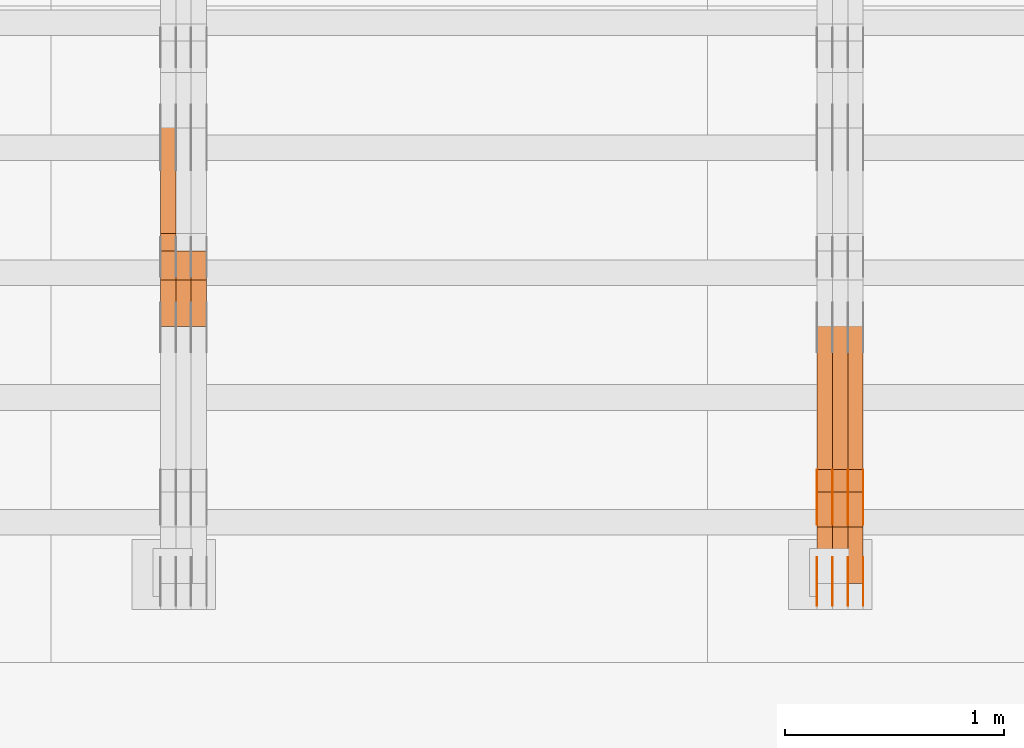
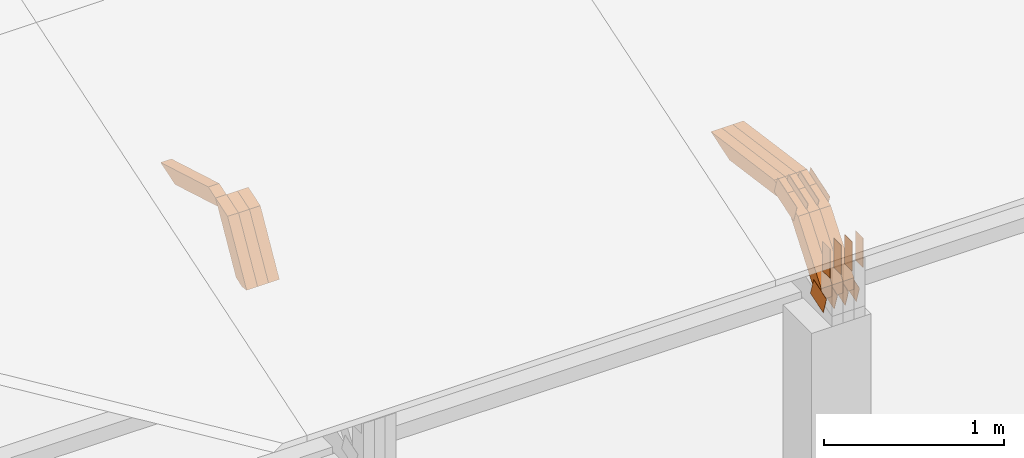
# One storey, part 123 of 385: 28 proxies.
"""IFC2X3 building model written with IfcOpenShell, lengths in millimetres."""

from ifc_helpers import new_model, entity, si_unit, converted_unit, derived_unit, direction, frame, frame_2d, origin, place, context, subcontext, project, spatial, polyline, rectangle, outline, extrude, source, transform, mapped, material, type_object, type_shapes, element, save


model = new_model("IFC2X3")

# Units and contexts
model_context = context("Model", 3, precision=0.01, world=origin(), true_north=direction((6.12303176911189e-17, 1.0)))
body_context = subcontext(model_context, "Body", "Model", "MODEL_VIEW")
ifc_project = project(units=[si_unit("LENGTHUNIT", "METRE", prefix="MILLI"), si_unit("AREAUNIT", "SQUARE_METRE"), si_unit("VOLUMEUNIT", "CUBIC_METRE"), converted_unit("PLANEANGLEUNIT", "DEGREE", entity("IfcRatioMeasure", 0.0174532925199433), si_unit("PLANEANGLEUNIT", "RADIAN"), dimensions=[0, 0, 0, 0, 0, 0, 0]), si_unit("MASSUNIT", "GRAM", prefix="KILO"), derived_unit("MASSDENSITYUNIT", [(si_unit("MASSUNIT", "GRAM", prefix="KILO"), 1), (si_unit("LENGTHUNIT", "METRE"), -3)]), si_unit("TIMEUNIT", "SECOND"), si_unit("FREQUENCYUNIT", "HERTZ"), si_unit("THERMODYNAMICTEMPERATUREUNIT", "DEGREE_CELSIUS"), derived_unit("THERMALTRANSMITTANCEUNIT", [(si_unit("MASSUNIT", "GRAM", prefix="KILO"), 1), (si_unit("THERMODYNAMICTEMPERATUREUNIT", "KELVIN"), -1), (si_unit("TIMEUNIT", "SECOND"), -3)]), derived_unit("VOLUMETRICFLOWRATEUNIT", [(si_unit("LENGTHUNIT", "METRE"), 3), (si_unit("TIMEUNIT", "SECOND"), -1)]), si_unit("ELECTRICCURRENTUNIT", "AMPERE"), si_unit("ELECTRICVOLTAGEUNIT", "VOLT"), si_unit("POWERUNIT", "WATT"), si_unit("FORCEUNIT", "NEWTON", prefix="KILO"), si_unit("ILLUMINANCEUNIT", "LUX"), si_unit("LUMINOUSFLUXUNIT", "LUMEN"), si_unit("LUMINOUSINTENSITYUNIT", "CANDELA"), derived_unit("USERDEFINED", [(si_unit("MASSUNIT", "GRAM", prefix="KILO"), -1), (si_unit("LENGTHUNIT", "METRE"), -2), (si_unit("TIMEUNIT", "SECOND"), 3), (si_unit("LUMINOUSFLUXUNIT", "LUMEN"), 1)]), derived_unit("LINEARVELOCITYUNIT", [(si_unit("LENGTHUNIT", "METRE"), 1), (si_unit("TIMEUNIT", "SECOND"), -1)]), si_unit("PRESSUREUNIT", "PASCAL"), derived_unit("USERDEFINED", [(si_unit("LENGTHUNIT", "METRE"), -2), (si_unit("MASSUNIT", "GRAM", prefix="KILO"), 1), (si_unit("TIMEUNIT", "SECOND"), -2)])], contexts=[model_context])

# Site, building, storey
site_placement = place(None, origin())
site = spatial("IfcSite", under=ifc_project, at=site_placement, CompositionType="ELEMENT")
building_placement = place(site_placement, origin())
building = spatial("IfcBuilding", under=site, at=building_placement, CompositionType="ELEMENT")
storey_placement = place(building_placement, origin())
storey = spatial("IfcBuildingStorey", under=building, at=storey_placement, Name="Default", CompositionType="ELEMENT", Elevation=0.0)

# Proxies
ifc_material_1 = material(Name="IfcSurfaceStyle #340028")
building_element_proxy_type_1 = type_object("IfcBuildingElementProxyType", PredefinedType="NOTDEFINED", material=ifc_material_1)
shared_shape_1 = source(origin(), body_context, "Body", "SweptSolid", [
    extrude(outline(polyline([(-74.999865408764, -60.0000379172698), (74.9998729365771, -60.0000379172698), (74.9998642299588, 60.0000379172698), (-74.9998717577719, 60.0000379172698), (-74.999865408764, -60.0000379172698)])), frame((75.0005044383734, 60.0001679035349, 0.0), z_axis=(0.0, 0.0, 1.0), x_axis=(-1.0, 0.0, 0.0)), (0.0, 0.0, 1.0), 1.3),
])
type_shapes(building_element_proxy_type_1, [shared_shape_1])
proxy_1_placement = place(building_placement, frame((27386.3, 2998.66143710398, 150.423871180894), z_axis=(-1.0, 0.0, 0.0), x_axis=(0.0, 0.951056516295124, 0.309016994375039)))
element("IfcBuildingElementProxy", 1, at=proxy_1_placement, inside=storey, type_object=building_element_proxy_type_1, material=ifc_material_1, context=body_context, shape_type="MappedRepresentation", body=[
    mapped(shared_shape_1, transform((0.0, 0.0, 0.0), scale=1.0)),
])
ifc_material_2 = material(Name="IfcSurfaceStyle #339971")
building_element_proxy_type_2 = type_object("IfcBuildingElementProxyType", PredefinedType="NOTDEFINED", material=ifc_material_2)
shared_shape_2 = source(origin(), body_context, "Body", "SweptSolid", [
    extrude(outline(polyline([(-74.999865408764, -60.0000379172698), (74.9998729365771, -60.0000379172698), (74.9998642299588, 60.0000379172698), (-74.9998717577719, 60.0000379172698), (-74.999865408764, -60.0000379172698)])), frame((75.0005044383734, 60.0001679035349, 0.0), z_axis=(0.0, 0.0, 1.0), x_axis=(-1.0, 0.0, 0.0)), (0.0, 0.0, 1.0), 1.3),
])
type_shapes(building_element_proxy_type_2, [shared_shape_2])
proxy_2_placement = place(building_placement, frame((27315.0, 2998.66143710398, 150.423871180894), z_axis=(-1.0, 0.0, 0.0), x_axis=(0.0, 0.951056516295124, 0.309016994375039)))
element("IfcBuildingElementProxy", 2, at=proxy_2_placement, inside=storey, type_object=building_element_proxy_type_2, material=ifc_material_2, context=body_context, shape_type="MappedRepresentation", body=[
    mapped(shared_shape_2, transform((0.0, 0.0, 0.0), scale=1.0)),
])
ifc_material_3 = material(Name="IfcSurfaceStyle #339914")
building_element_proxy_type_3 = type_object("IfcBuildingElementProxyType", PredefinedType="NOTDEFINED", material=ifc_material_3)
shared_shape_3 = source(origin(), body_context, "Body", "SweptSolid", [
    extrude(outline(polyline([(-74.999865408764, -60.0000379172698), (74.9998729365771, -60.0000379172698), (74.9998642299588, 60.0000379172698), (-74.9998717577719, 60.0000379172698), (-74.999865408764, -60.0000379172698)])), frame((75.0005044383734, 60.0001679035349, 0.0), z_axis=(0.0, 0.0, 1.0), x_axis=(-1.0, 0.0, 0.0)), (0.0, 0.0, 1.0), 1.3),
])
type_shapes(building_element_proxy_type_3, [shared_shape_3])
proxy_3_placement = place(building_placement, frame((27316.3, 2998.66143710398, 150.423871180894), z_axis=(-1.0, 0.0, 0.0), x_axis=(0.0, 0.951056516295124, 0.309016994375039)))
element("IfcBuildingElementProxy", 3, at=proxy_3_placement, inside=storey, type_object=building_element_proxy_type_3, material=ifc_material_3, context=body_context, shape_type="MappedRepresentation", body=[
    mapped(shared_shape_3, transform((0.0, 0.0, 0.0), scale=1.0)),
])
ifc_material_4 = material(Name="IfcSurfaceStyle #339857")
building_element_proxy_type_4 = type_object("IfcBuildingElementProxyType", PredefinedType="NOTDEFINED", material=ifc_material_4)
shared_shape_4 = source(origin(), body_context, "Body", "SweptSolid", [
    extrude(outline(polyline([(-74.999865408764, -60.0000379172698), (74.9998729365771, -60.0000379172698), (74.9998642299588, 60.0000379172698), (-74.9998717577719, 60.0000379172698), (-74.999865408764, -60.0000379172698)])), frame((75.0005044383734, 60.0001679035349, 0.0), z_axis=(0.0, 0.0, 1.0), x_axis=(-1.0, 0.0, 0.0)), (0.0, 0.0, 1.0), 1.29999999999999),
])
type_shapes(building_element_proxy_type_4, [shared_shape_4])
proxy_4_placement = place(building_placement, frame((27245.0, 2998.66143710398, 150.423871180894), z_axis=(-1.0, 0.0, 0.0), x_axis=(0.0, 0.951056516295124, 0.309016994375039)))
element("IfcBuildingElementProxy", 4, at=proxy_4_placement, inside=storey, type_object=building_element_proxy_type_4, material=ifc_material_4, context=body_context, shape_type="MappedRepresentation", body=[
    mapped(shared_shape_4, transform((0.0, 0.0, 0.0), scale=1.0)),
])
ifc_material_5 = material(Name="IfcSurfaceStyle #339800")
building_element_proxy_type_5 = type_object("IfcBuildingElementProxyType", PredefinedType="NOTDEFINED", material=ifc_material_5)
shared_shape_5 = source(origin(), body_context, "Body", "SweptSolid", [
    extrude(outline(polyline([(-74.999865408764, -60.0000379172698), (74.9998729365771, -60.0000379172698), (74.9998642299588, 60.0000379172698), (-74.9998717577719, 60.0000379172698), (-74.999865408764, -60.0000379172698)])), frame((75.0005044383734, 60.0001679035349, 0.0), z_axis=(0.0, 0.0, 1.0), x_axis=(-1.0, 0.0, 0.0)), (0.0, 0.0, 1.0), 1.29999999999999),
])
type_shapes(building_element_proxy_type_5, [shared_shape_5])
proxy_5_placement = place(building_placement, frame((27246.3, 2998.66143710398, 150.423871180894), z_axis=(-1.0, 0.0, 0.0), x_axis=(0.0, 0.951056516295124, 0.309016994375039)))
element("IfcBuildingElementProxy", 5, at=proxy_5_placement, inside=storey, type_object=building_element_proxy_type_5, material=ifc_material_5, context=body_context, shape_type="MappedRepresentation", body=[
    mapped(shared_shape_5, transform((0.0, 0.0, 0.0), scale=1.0)),
])
ifc_material_6 = material(Name="IfcSurfaceStyle #339743")
building_element_proxy_type_6 = type_object("IfcBuildingElementProxyType", PredefinedType="NOTDEFINED", material=ifc_material_6)
shared_shape_6 = source(origin(), body_context, "Body", "SweptSolid", [
    extrude(outline(polyline([(-74.999865408764, -60.0000379172698), (74.9998729365771, -60.0000379172698), (74.9998642299588, 60.0000379172698), (-74.9998717577719, 60.0000379172698), (-74.999865408764, -60.0000379172698)])), frame((75.0005044383734, 60.0001679035349, 0.0), z_axis=(0.0, 0.0, 1.0), x_axis=(-1.0, 0.0, 0.0)), (0.0, 0.0, 1.0), 1.29999999999999),
])
type_shapes(building_element_proxy_type_6, [shared_shape_6])
proxy_6_placement = place(building_placement, frame((27175.0, 2998.66143710398, 150.423871180894), z_axis=(-1.0, 0.0, 0.0), x_axis=(0.0, 0.951056516295124, 0.309016994375039)))
element("IfcBuildingElementProxy", 6, at=proxy_6_placement, inside=storey, type_object=building_element_proxy_type_6, material=ifc_material_6, context=body_context, shape_type="MappedRepresentation", body=[
    mapped(shared_shape_6, transform((0.0, 0.0, 0.0), scale=1.0)),
])
ifc_material_7 = material(Name="IfcSurfaceStyle #331478")
building_element_proxy_type_7 = type_object("IfcBuildingElementProxyType", PredefinedType="NOTDEFINED", material=ifc_material_7)
shared_shape_7 = source(origin(), body_context, "Body", "SweptSolid", [
    extrude(outline(polyline([(-112.500266735783, -59.9999130784581), (112.500275442392, -59.9999130784581), (112.500262020557, 59.9999130784582), (-112.500270727166, 59.9999130784581), (-112.500266735783, -59.9999130784581)])), frame((112.500275442392, 60.0001020984692, 0.0), z_axis=(0.0, 0.0, 1.0), x_axis=(-1.0, 0.0, 0.0)), (0.0, 0.0, 1.0), 1.3),
])
type_shapes(building_element_proxy_type_7, [shared_shape_7])
proxy_7_placement = place(building_placement, frame((27386.3, 3327.32420598508, 571.284602786019), z_axis=(-1.0, 0.0, 0.0), x_axis=(0.0, 0.951056516295154, 0.309016994374948)))
element("IfcBuildingElementProxy", 7, at=proxy_7_placement, inside=storey, type_object=building_element_proxy_type_7, material=ifc_material_7, context=body_context, shape_type="MappedRepresentation", body=[
    mapped(shared_shape_7, transform((0.0, 0.0, 0.0), scale=1.0)),
])
ifc_material_8 = material(Name="IfcSurfaceStyle #331421")
building_element_proxy_type_8 = type_object("IfcBuildingElementProxyType", PredefinedType="NOTDEFINED", material=ifc_material_8)
shared_shape_8 = source(origin(), body_context, "Body", "SweptSolid", [
    extrude(outline(polyline([(-112.500266735783, -59.9999130784581), (112.500275442392, -59.9999130784581), (112.500262020557, 59.9999130784582), (-112.500270727166, 59.9999130784581), (-112.500266735783, -59.9999130784581)])), frame((112.500275442392, 60.0001020984692, 0.0), z_axis=(0.0, 0.0, 1.0), x_axis=(-1.0, 0.0, 0.0)), (0.0, 0.0, 1.0), 1.3),
])
type_shapes(building_element_proxy_type_8, [shared_shape_8])
proxy_8_placement = place(building_placement, frame((27315.0, 3327.32420598508, 571.284602786019), z_axis=(-1.0, 0.0, 0.0), x_axis=(0.0, 0.951056516295154, 0.309016994374948)))
element("IfcBuildingElementProxy", 8, at=proxy_8_placement, inside=storey, type_object=building_element_proxy_type_8, material=ifc_material_8, context=body_context, shape_type="MappedRepresentation", body=[
    mapped(shared_shape_8, transform((0.0, 0.0, 0.0), scale=1.0)),
])
ifc_material_9 = material(Name="IfcSurfaceStyle #331364")
building_element_proxy_type_9 = type_object("IfcBuildingElementProxyType", PredefinedType="NOTDEFINED", material=ifc_material_9)
shared_shape_9 = source(origin(), body_context, "Body", "SweptSolid", [
    extrude(outline(polyline([(-112.500266735783, -59.9999130784581), (112.500275442392, -59.9999130784581), (112.500262020557, 59.9999130784582), (-112.500270727166, 59.9999130784581), (-112.500266735783, -59.9999130784581)])), frame((112.500275442392, 60.0001020984692, 0.0), z_axis=(0.0, 0.0, 1.0), x_axis=(-1.0, 0.0, 0.0)), (0.0, 0.0, 1.0), 1.3),
])
type_shapes(building_element_proxy_type_9, [shared_shape_9])
proxy_9_placement = place(building_placement, frame((27316.3, 3327.32420598508, 571.284602786019), z_axis=(-1.0, 0.0, 0.0), x_axis=(0.0, 0.951056516295154, 0.309016994374948)))
element("IfcBuildingElementProxy", 9, at=proxy_9_placement, inside=storey, type_object=building_element_proxy_type_9, material=ifc_material_9, context=body_context, shape_type="MappedRepresentation", body=[
    mapped(shared_shape_9, transform((0.0, 0.0, 0.0), scale=1.0)),
])
ifc_material_10 = material(Name="IfcSurfaceStyle #331307")
building_element_proxy_type_10 = type_object("IfcBuildingElementProxyType", PredefinedType="NOTDEFINED", material=ifc_material_10)
shared_shape_10 = source(origin(), body_context, "Body", "SweptSolid", [
    extrude(outline(polyline([(-112.500266735783, -59.9999130784581), (112.500275442392, -59.9999130784581), (112.500262020557, 59.9999130784582), (-112.500270727166, 59.9999130784581), (-112.500266735783, -59.9999130784581)])), frame((112.500275442392, 60.0001020984692, 0.0), z_axis=(0.0, 0.0, 1.0), x_axis=(-1.0, 0.0, 0.0)), (0.0, 0.0, 1.0), 1.29999999999998),
])
type_shapes(building_element_proxy_type_10, [shared_shape_10])
proxy_10_placement = place(building_placement, frame((27245.0, 3327.32420598508, 571.284602786019), z_axis=(-1.0, 0.0, 0.0), x_axis=(0.0, 0.951056516295154, 0.309016994374948)))
element("IfcBuildingElementProxy", 10, at=proxy_10_placement, inside=storey, type_object=building_element_proxy_type_10, material=ifc_material_10, context=body_context, shape_type="MappedRepresentation", body=[
    mapped(shared_shape_10, transform((0.0, 0.0, 0.0), scale=1.0)),
])
ifc_material_11 = material(Name="IfcSurfaceStyle #331250")
building_element_proxy_type_11 = type_object("IfcBuildingElementProxyType", PredefinedType="NOTDEFINED", material=ifc_material_11)
shared_shape_11 = source(origin(), body_context, "Body", "SweptSolid", [
    extrude(outline(polyline([(-112.500266735783, -59.9999130784581), (112.500275442392, -59.9999130784581), (112.500262020557, 59.9999130784582), (-112.500270727166, 59.9999130784581), (-112.500266735783, -59.9999130784581)])), frame((112.500275442392, 60.0001020984692, 0.0), z_axis=(0.0, 0.0, 1.0), x_axis=(-1.0, 0.0, 0.0)), (0.0, 0.0, 1.0), 1.29999999999998),
])
type_shapes(building_element_proxy_type_11, [shared_shape_11])
proxy_11_placement = place(building_placement, frame((27246.3, 3327.32420598508, 571.284602786019), z_axis=(-1.0, 0.0, 0.0), x_axis=(0.0, 0.951056516295154, 0.309016994374948)))
element("IfcBuildingElementProxy", 11, at=proxy_11_placement, inside=storey, type_object=building_element_proxy_type_11, material=ifc_material_11, context=body_context, shape_type="MappedRepresentation", body=[
    mapped(shared_shape_11, transform((0.0, 0.0, 0.0), scale=1.0)),
])
ifc_material_12 = material(Name="IfcSurfaceStyle #331193")
building_element_proxy_type_12 = type_object("IfcBuildingElementProxyType", PredefinedType="NOTDEFINED", material=ifc_material_12)
shared_shape_12 = source(origin(), body_context, "Body", "SweptSolid", [
    extrude(outline(polyline([(-112.500266735783, -59.9999130784581), (112.500275442392, -59.9999130784581), (112.500262020557, 59.9999130784582), (-112.500270727166, 59.9999130784581), (-112.500266735783, -59.9999130784581)])), frame((112.500275442392, 60.0001020984692, 0.0), z_axis=(0.0, 0.0, 1.0), x_axis=(-1.0, 0.0, 0.0)), (0.0, 0.0, 1.0), 1.29999999999999),
])
type_shapes(building_element_proxy_type_12, [shared_shape_12])
proxy_12_placement = place(building_placement, frame((27175.0, 3327.32420598508, 571.284602786019), z_axis=(-1.0, 0.0, 0.0), x_axis=(0.0, 0.951056516295154, 0.309016994374948)))
element("IfcBuildingElementProxy", 12, at=proxy_12_placement, inside=storey, type_object=building_element_proxy_type_12, material=ifc_material_12, context=body_context, shape_type="MappedRepresentation", body=[
    mapped(shared_shape_12, transform((0.0, 0.0, 0.0), scale=1.0)),
])
ifc_material_13 = material(Name="IfcSurfaceStyle #330452")
building_element_proxy_type_13 = type_object("IfcBuildingElementProxyType", PredefinedType="NOTDEFINED", material=ifc_material_13)
shared_shape_13 = source(origin(), body_context, "Body", "SweptSolid", [
    extrude(rectangle(XDim=199.999969482422, YDim=84.0, at=frame_2d((1.4210854715202e-14, 0.0), x_axis=(1.0, 0.0))), frame((100.000010815955, 42.0, 0.0), z_axis=(0.0, 0.0, 1.0), x_axis=(-1.0, 0.0, 0.0)), (0.0, 0.0, 1.0), 1.3),
])
type_shapes(building_element_proxy_type_13, [shared_shape_13])
proxy_13_placement = place(building_placement, frame((27386.3, 3042.0, 514.460048047401), z_axis=(-1.0, 0.0, 0.0), x_axis=(0.0, 0.0, -1.0)))
element("IfcBuildingElementProxy", 13, at=proxy_13_placement, inside=storey, type_object=building_element_proxy_type_13, material=ifc_material_13, context=body_context, shape_type="MappedRepresentation", body=[
    mapped(shared_shape_13, transform((0.0, 0.0, 0.0), scale=1.0)),
])
ifc_material_14 = material(Name="IfcSurfaceStyle #330395")
building_element_proxy_type_14 = type_object("IfcBuildingElementProxyType", PredefinedType="NOTDEFINED", material=ifc_material_14)
shared_shape_14 = source(origin(), body_context, "Body", "SweptSolid", [
    extrude(rectangle(XDim=199.999969482422, YDim=84.0, at=frame_2d((1.4210854715202e-14, 0.0), x_axis=(1.0, 0.0))), frame((100.000010815955, 42.0, 0.0), z_axis=(0.0, 0.0, 1.0), x_axis=(-1.0, 0.0, 0.0)), (0.0, 0.0, 1.0), 1.3),
])
type_shapes(building_element_proxy_type_14, [shared_shape_14])
proxy_14_placement = place(building_placement, frame((27315.0, 3042.0, 514.460048047401), z_axis=(-1.0, 0.0, 0.0), x_axis=(0.0, 0.0, -1.0)))
element("IfcBuildingElementProxy", 14, at=proxy_14_placement, inside=storey, type_object=building_element_proxy_type_14, material=ifc_material_14, context=body_context, shape_type="MappedRepresentation", body=[
    mapped(shared_shape_14, transform((0.0, 0.0, 0.0), scale=1.0)),
])
ifc_material_15 = material(Name="IfcSurfaceStyle #330338")
building_element_proxy_type_15 = type_object("IfcBuildingElementProxyType", PredefinedType="NOTDEFINED", material=ifc_material_15)
shared_shape_15 = source(origin(), body_context, "Body", "SweptSolid", [
    extrude(rectangle(XDim=199.999969482422, YDim=84.0, at=frame_2d((1.4210854715202e-14, 0.0), x_axis=(1.0, 0.0))), frame((100.000010815955, 42.0, 0.0), z_axis=(0.0, 0.0, 1.0), x_axis=(-1.0, 0.0, 0.0)), (0.0, 0.0, 1.0), 1.3),
])
type_shapes(building_element_proxy_type_15, [shared_shape_15])
proxy_15_placement = place(building_placement, frame((27316.3, 3042.0, 514.460048047401), z_axis=(-1.0, 0.0, 0.0), x_axis=(0.0, 0.0, -1.0)))
element("IfcBuildingElementProxy", 15, at=proxy_15_placement, inside=storey, type_object=building_element_proxy_type_15, material=ifc_material_15, context=body_context, shape_type="MappedRepresentation", body=[
    mapped(shared_shape_15, transform((0.0, 0.0, 0.0), scale=1.0)),
])
ifc_material_16 = material(Name="IfcSurfaceStyle #330281")
building_element_proxy_type_16 = type_object("IfcBuildingElementProxyType", PredefinedType="NOTDEFINED", material=ifc_material_16)
shared_shape_16 = source(origin(), body_context, "Body", "SweptSolid", [
    extrude(rectangle(XDim=199.999969482422, YDim=84.0, at=frame_2d((1.4210854715202e-14, 0.0), x_axis=(1.0, 0.0))), frame((100.000010815955, 42.0, 0.0), z_axis=(0.0, 0.0, 1.0), x_axis=(-1.0, 0.0, 0.0)), (0.0, 0.0, 1.0), 1.29999999999998),
])
type_shapes(building_element_proxy_type_16, [shared_shape_16])
proxy_16_placement = place(building_placement, frame((27245.0, 3042.0, 514.460048047401), z_axis=(-1.0, 0.0, 0.0), x_axis=(0.0, 0.0, -1.0)))
element("IfcBuildingElementProxy", 16, at=proxy_16_placement, inside=storey, type_object=building_element_proxy_type_16, material=ifc_material_16, context=body_context, shape_type="MappedRepresentation", body=[
    mapped(shared_shape_16, transform((0.0, 0.0, 0.0), scale=1.0)),
])
ifc_material_17 = material(Name="IfcSurfaceStyle #330224")
building_element_proxy_type_17 = type_object("IfcBuildingElementProxyType", PredefinedType="NOTDEFINED", material=ifc_material_17)
shared_shape_17 = source(origin(), body_context, "Body", "SweptSolid", [
    extrude(rectangle(XDim=199.999969482422, YDim=84.0, at=frame_2d((1.4210854715202e-14, 0.0), x_axis=(1.0, 0.0))), frame((100.000010815955, 42.0, 0.0), z_axis=(0.0, 0.0, 1.0), x_axis=(-1.0, 0.0, 0.0)), (0.0, 0.0, 1.0), 1.29999999999998),
])
type_shapes(building_element_proxy_type_17, [shared_shape_17])
proxy_17_placement = place(building_placement, frame((27246.3, 3042.0, 514.460048047401), z_axis=(-1.0, 0.0, 0.0), x_axis=(0.0, 0.0, -1.0)))
element("IfcBuildingElementProxy", 17, at=proxy_17_placement, inside=storey, type_object=building_element_proxy_type_17, material=ifc_material_17, context=body_context, shape_type="MappedRepresentation", body=[
    mapped(shared_shape_17, transform((0.0, 0.0, 0.0), scale=1.0)),
])
ifc_material_18 = material(Name="IfcSurfaceStyle #330167")
building_element_proxy_type_18 = type_object("IfcBuildingElementProxyType", PredefinedType="NOTDEFINED", material=ifc_material_18)
shared_shape_18 = source(origin(), body_context, "Body", "SweptSolid", [
    extrude(rectangle(XDim=199.999969482422, YDim=84.0, at=frame_2d((1.4210854715202e-14, 0.0), x_axis=(1.0, 0.0))), frame((100.000010815955, 42.0, 0.0), z_axis=(0.0, 0.0, 1.0), x_axis=(-1.0, 0.0, 0.0)), (0.0, 0.0, 1.0), 1.29999999999999),
])
type_shapes(building_element_proxy_type_18, [shared_shape_18])
proxy_18_placement = place(building_placement, frame((27175.0, 3042.0, 514.460048047401), z_axis=(-1.0, 0.0, 0.0), x_axis=(0.0, 0.0, -1.0)))
element("IfcBuildingElementProxy", 18, at=proxy_18_placement, inside=storey, type_object=building_element_proxy_type_18, material=ifc_material_18, context=body_context, shape_type="MappedRepresentation", body=[
    mapped(shared_shape_18, transform((0.0, 0.0, 0.0), scale=1.0)),
])
ifc_material_19 = material(Name="IfcSurfaceStyle #319184")
building_element_proxy_type_19 = type_object("IfcBuildingElementProxyType", Name="T1-W3 319182", PredefinedType="NOTDEFINED", material=ifc_material_19)
shared_shape_19 = source(origin(), body_context, "Body", "SweptSolid", [
    extrude(outline(polyline([(-314.232579911788, -47.5000200125938), (325.164873061766, -47.5000200125938), (297.999869081008, 6.48085173424295e-05), (200.434027234171, 47.4999876083351), (-509.366189465157, 47.4999876083352), (-314.232579911788, -47.5000200125938)])), frame((325.164873061766, 47.5001564752191, 0.0), z_axis=(0.0, 0.0, 1.0), x_axis=(-1.0, 0.0, 0.0)), (0.0, 0.0, 1.0), 70.0),
])
type_shapes(building_element_proxy_type_19, [shared_shape_19])
proxy_19_placement = place(building_placement, frame((27385.0, 3457.43747924876, 620.49890325051), z_axis=(-1.0, 0.0, 0.0), x_axis=(0.0, 0.990367219823621, -0.138465771578512)))
element("IfcBuildingElementProxy", 19, at=proxy_19_placement, inside=storey, type_object=building_element_proxy_type_19, material=ifc_material_19, Name="T1-W3", context=body_context, shape_type="MappedRepresentation", body=[
    mapped(shared_shape_19, transform((0.0, 0.0, 0.0), scale=1.0)),
])
ifc_material_20 = material(Name="IfcSurfaceStyle #319118")
building_element_proxy_type_20 = type_object("IfcBuildingElementProxyType", Name="T1-W3 319116", PredefinedType="NOTDEFINED", material=ifc_material_20)
shared_shape_20 = source(origin(), body_context, "Body", "SweptSolid", [
    extrude(outline(polyline([(-314.232579911788, -47.5000200125938), (325.164873061766, -47.5000200125938), (297.999869081008, 6.48085173424295e-05), (200.434027234171, 47.4999876083351), (-509.366189465157, 47.4999876083352), (-314.232579911788, -47.5000200125938)])), frame((325.164873061766, 47.5001564752191, 0.0), z_axis=(0.0, 0.0, 1.0), x_axis=(-1.0, 0.0, 0.0)), (0.0, 0.0, 1.0), 70.0),
])
type_shapes(building_element_proxy_type_20, [shared_shape_20])
proxy_20_placement = place(building_placement, frame((27315.0, 3457.43747924876, 620.49890325051), z_axis=(-1.0, 0.0, 0.0), x_axis=(0.0, 0.990367219823621, -0.138465771578512)))
element("IfcBuildingElementProxy", 20, at=proxy_20_placement, inside=storey, type_object=building_element_proxy_type_20, material=ifc_material_20, Name="T1-W3", context=body_context, shape_type="MappedRepresentation", body=[
    mapped(shared_shape_20, transform((0.0, 0.0, 0.0), scale=1.0)),
])
ifc_material_21 = material(Name="IfcSurfaceStyle #319052")
building_element_proxy_type_21 = type_object("IfcBuildingElementProxyType", Name="T1-W3 319050", PredefinedType="NOTDEFINED", material=ifc_material_21)
shared_shape_21 = source(origin(), body_context, "Body", "SweptSolid", [
    extrude(outline(polyline([(-314.232579911788, -47.5000200125938), (325.164873061766, -47.5000200125938), (297.999869081008, 6.48085173424295e-05), (200.434027234171, 47.4999876083351), (-509.366189465157, 47.4999876083352), (-314.232579911788, -47.5000200125938)])), frame((325.164873061766, 47.5001564752191, 0.0), z_axis=(0.0, 0.0, 1.0), x_axis=(-1.0, 0.0, 0.0)), (0.0, 0.0, 1.0), 70.0),
])
type_shapes(building_element_proxy_type_21, [shared_shape_21])
proxy_21_placement = place(building_placement, frame((27245.0, 3457.43747924876, 620.49890325051), z_axis=(-1.0, 0.0, 0.0), x_axis=(0.0, 0.990367219823621, -0.138465771578512)))
element("IfcBuildingElementProxy", 21, at=proxy_21_placement, inside=storey, type_object=building_element_proxy_type_21, material=ifc_material_21, Name="T1-W3", context=body_context, shape_type="MappedRepresentation", body=[
    mapped(shared_shape_21, transform((0.0, 0.0, 0.0), scale=1.0)),
])
ifc_material_22 = material(Name="IfcSurfaceStyle #318788")
building_element_proxy_type_22 = type_object("IfcBuildingElementProxyType", Name="T1-W14 318786", PredefinedType="NOTDEFINED", material=ifc_material_22)
shared_shape_22 = source(origin(), body_context, "Body", "SweptSolid", [
    extrude(outline(polyline([(-374.484689776928, -47.499919737532), (177.199556189275, -47.499919737532), (246.893257937645, -5.36774925340877e-05), (185.487930694801, 47.4999465762783), (-235.096055044793, 47.4999465762784), (-374.484689776928, -47.499919737532)])), frame((246.893257937645, 47.5000959779252, 0.0), z_axis=(0.0, 0.0, 1.0), x_axis=(-1.0, 0.0, 0.0)), (0.0, 0.0, 1.0), 70.0),
])
type_shapes(building_element_proxy_type_22, [shared_shape_22])
proxy_22_placement = place(building_placement, frame((27385.0, 3022.42877773025, 136.329406512195), z_axis=(-1.0, 0.0, 0.0), x_axis=(0.0, 0.611854146609475, 0.790970608352037)))
element("IfcBuildingElementProxy", 22, at=proxy_22_placement, inside=storey, type_object=building_element_proxy_type_22, material=ifc_material_22, Name="T1-W14", context=body_context, shape_type="MappedRepresentation", body=[
    mapped(shared_shape_22, transform((0.0, 0.0, 0.0), scale=1.0)),
])
ifc_material_23 = material(Name="IfcSurfaceStyle #318722")
building_element_proxy_type_23 = type_object("IfcBuildingElementProxyType", Name="T1-W14 318720", PredefinedType="NOTDEFINED", material=ifc_material_23)
shared_shape_23 = source(origin(), body_context, "Body", "SweptSolid", [
    extrude(outline(polyline([(-374.484689776928, -47.499919737532), (177.199556189275, -47.499919737532), (246.893257937645, -5.36774925340877e-05), (185.487930694801, 47.4999465762783), (-235.096055044793, 47.4999465762784), (-374.484689776928, -47.499919737532)])), frame((246.893257937645, 47.5000959779252, 0.0), z_axis=(0.0, 0.0, 1.0), x_axis=(-1.0, 0.0, 0.0)), (0.0, 0.0, 1.0), 70.0),
])
type_shapes(building_element_proxy_type_23, [shared_shape_23])
proxy_23_placement = place(building_placement, frame((27315.0, 3022.42877773025, 136.329406512195), z_axis=(-1.0, 0.0, 0.0), x_axis=(0.0, 0.611854146609475, 0.790970608352037)))
element("IfcBuildingElementProxy", 23, at=proxy_23_placement, inside=storey, type_object=building_element_proxy_type_23, material=ifc_material_23, Name="T1-W14", context=body_context, shape_type="MappedRepresentation", body=[
    mapped(shared_shape_23, transform((0.0, 0.0, 0.0), scale=1.0)),
])
ifc_material_24 = material(Name="IfcSurfaceStyle #318656")
building_element_proxy_type_24 = type_object("IfcBuildingElementProxyType", Name="T1-W14 318654", PredefinedType="NOTDEFINED", material=ifc_material_24)
shared_shape_24 = source(origin(), body_context, "Body", "SweptSolid", [
    extrude(outline(polyline([(-374.484689776928, -47.499919737532), (177.199556189275, -47.499919737532), (246.893257937645, -5.36774925340877e-05), (185.487930694801, 47.4999465762783), (-235.096055044793, 47.4999465762784), (-374.484689776928, -47.499919737532)])), frame((246.893257937645, 47.5000959779252, 0.0), z_axis=(0.0, 0.0, 1.0), x_axis=(-1.0, 0.0, 0.0)), (0.0, 0.0, 1.0), 70.0),
])
type_shapes(building_element_proxy_type_24, [shared_shape_24])
proxy_24_placement = place(building_placement, frame((27245.0, 3022.42877773025, 136.329406512195), z_axis=(-1.0, 0.0, 0.0), x_axis=(0.0, 0.611854146609475, 0.790970608352037)))
element("IfcBuildingElementProxy", 24, at=proxy_24_placement, inside=storey, type_object=building_element_proxy_type_24, material=ifc_material_24, Name="T1-W14", context=body_context, shape_type="MappedRepresentation", body=[
    mapped(shared_shape_24, transform((0.0, 0.0, 0.0), scale=1.0)),
])
ifc_material_25 = material(Name="IfcSurfaceStyle #285412")
building_element_proxy_type_25 = type_object("IfcBuildingElementProxyType", Name="T1-W12 285410", PredefinedType="NOTDEFINED", material=ifc_material_25)
shared_shape_25 = source(origin(), body_context, "Body", "SweptSolid", [
    extrude(outline(polyline([(-249.405625983165, -47.5001691155616), (243.345753908996, -47.5001691155616), (232.115534842595, 2.39993474701938e-05), (162.527010966644, 47.5001571158879), (-388.58267373507, 47.5001571158879), (-249.405625983165, -47.5001691155616)])), frame((243.345867653852, 47.5001571158879, 0.0), z_axis=(0.0, 0.0, 1.0), x_axis=(-1.0, 0.0, 0.0)), (0.0, 0.0, 1.0), 70.0),
])
type_shapes(building_element_proxy_type_25, [shared_shape_25])
proxy_25_placement = place(building_placement, frame((24245.0, 4581.32698473631, 976.172276753357), z_axis=(-1.0, 0.0, 0.0), x_axis=(0.0, 0.959722067881787, -0.280951156645966)))
element("IfcBuildingElementProxy", 25, at=proxy_25_placement, inside=storey, type_object=building_element_proxy_type_25, material=ifc_material_25, Name="T1-W12", context=body_context, shape_type="MappedRepresentation", body=[
    mapped(shared_shape_25, transform((0.0, 0.0, 0.0), scale=1.0)),
])
ifc_material_26 = material(Name="IfcSurfaceStyle #285148")
building_element_proxy_type_26 = type_object("IfcBuildingElementProxyType", Name="T1-W27 285146", PredefinedType="NOTDEFINED", material=ifc_material_26)
shared_shape_26 = source(origin(), body_context, "Body", "SweptSolid", [
    extrude(outline(polyline([(-321.979763159708, -47.49993999164), (138.960018341432, -47.49993999164), (191.013775341887, -0.000473170132329126), (209.87827169492, 47.5001765767061), (-217.872302218531, 47.5001765767062), (-321.979763159708, -47.49993999164)])), frame((209.87827169492, 47.5001765767061, 0.0), z_axis=(0.0, 0.0, 1.0), x_axis=(-1.0, 0.0, 0.0)), (0.0, 0.0, 1.0), 70.0),
])
type_shapes(building_element_proxy_type_26, [shared_shape_26])
proxy_26_placement = place(building_placement, frame((24385.0, 4233.3125, 512.021728515625), z_axis=(-1.0, 0.0, 0.0), x_axis=(0.0, 0.494231057369727, 0.869330582650352)))
element("IfcBuildingElementProxy", 26, at=proxy_26_placement, inside=storey, type_object=building_element_proxy_type_26, material=ifc_material_26, Name="T1-W27", context=body_context, shape_type="MappedRepresentation", body=[
    mapped(shared_shape_26, transform((0.0, 0.0, 0.0), scale=1.0)),
])
ifc_material_27 = material(Name="IfcSurfaceStyle #285082")
building_element_proxy_type_27 = type_object("IfcBuildingElementProxyType", Name="T1-W27 285080", PredefinedType="NOTDEFINED", material=ifc_material_27)
shared_shape_27 = source(origin(), body_context, "Body", "SweptSolid", [
    extrude(outline(polyline([(-321.979763159708, -47.49993999164), (138.960018341432, -47.49993999164), (191.013775341887, -0.000473170132329126), (209.87827169492, 47.5001765767061), (-217.872302218531, 47.5001765767062), (-321.979763159708, -47.49993999164)])), frame((209.87827169492, 47.5001765767061, 0.0), z_axis=(0.0, 0.0, 1.0), x_axis=(-1.0, 0.0, 0.0)), (0.0, 0.0, 1.0), 70.0),
])
type_shapes(building_element_proxy_type_27, [shared_shape_27])
proxy_27_placement = place(building_placement, frame((24315.0, 4233.3125, 512.021728515625), z_axis=(-1.0, 0.0, 0.0), x_axis=(0.0, 0.494231057369727, 0.869330582650352)))
element("IfcBuildingElementProxy", 27, at=proxy_27_placement, inside=storey, type_object=building_element_proxy_type_27, material=ifc_material_27, Name="T1-W27", context=body_context, shape_type="MappedRepresentation", body=[
    mapped(shared_shape_27, transform((0.0, 0.0, 0.0), scale=1.0)),
])
ifc_material_28 = material(Name="IfcSurfaceStyle #285016")
building_element_proxy_type_28 = type_object("IfcBuildingElementProxyType", Name="T1-W27 285014", PredefinedType="NOTDEFINED", material=ifc_material_28)
shared_shape_28 = source(origin(), body_context, "Body", "SweptSolid", [
    extrude(outline(polyline([(-321.979763159708, -47.49993999164), (138.960018341432, -47.49993999164), (191.013775341887, -0.000473170132329126), (209.87827169492, 47.5001765767061), (-217.872302218531, 47.5001765767062), (-321.979763159708, -47.49993999164)])), frame((209.87827169492, 47.5001765767061, 0.0), z_axis=(0.0, 0.0, 1.0), x_axis=(-1.0, 0.0, 0.0)), (0.0, 0.0, 1.0), 70.0),
])
type_shapes(building_element_proxy_type_28, [shared_shape_28])
proxy_28_placement = place(building_placement, frame((24245.0, 4233.3125, 512.021728515625), z_axis=(-1.0, 0.0, 0.0), x_axis=(0.0, 0.494231057369727, 0.869330582650352)))
element("IfcBuildingElementProxy", 28, at=proxy_28_placement, inside=storey, type_object=building_element_proxy_type_28, material=ifc_material_28, Name="T1-W27", context=body_context, shape_type="MappedRepresentation", body=[
    mapped(shared_shape_28, transform((0.0, 0.0, 0.0), scale=1.0)),
])

save(model, "model.ifc")
